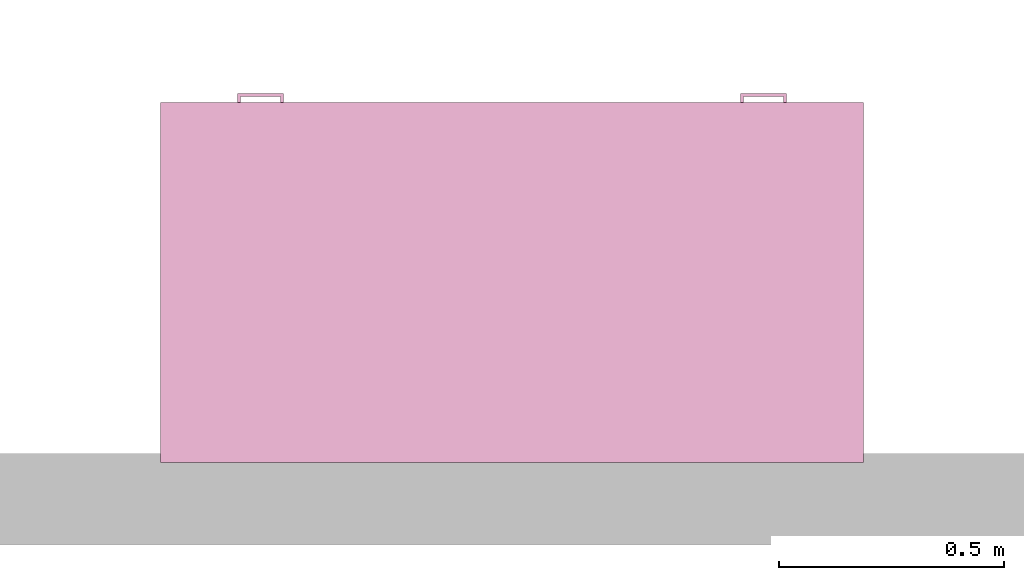
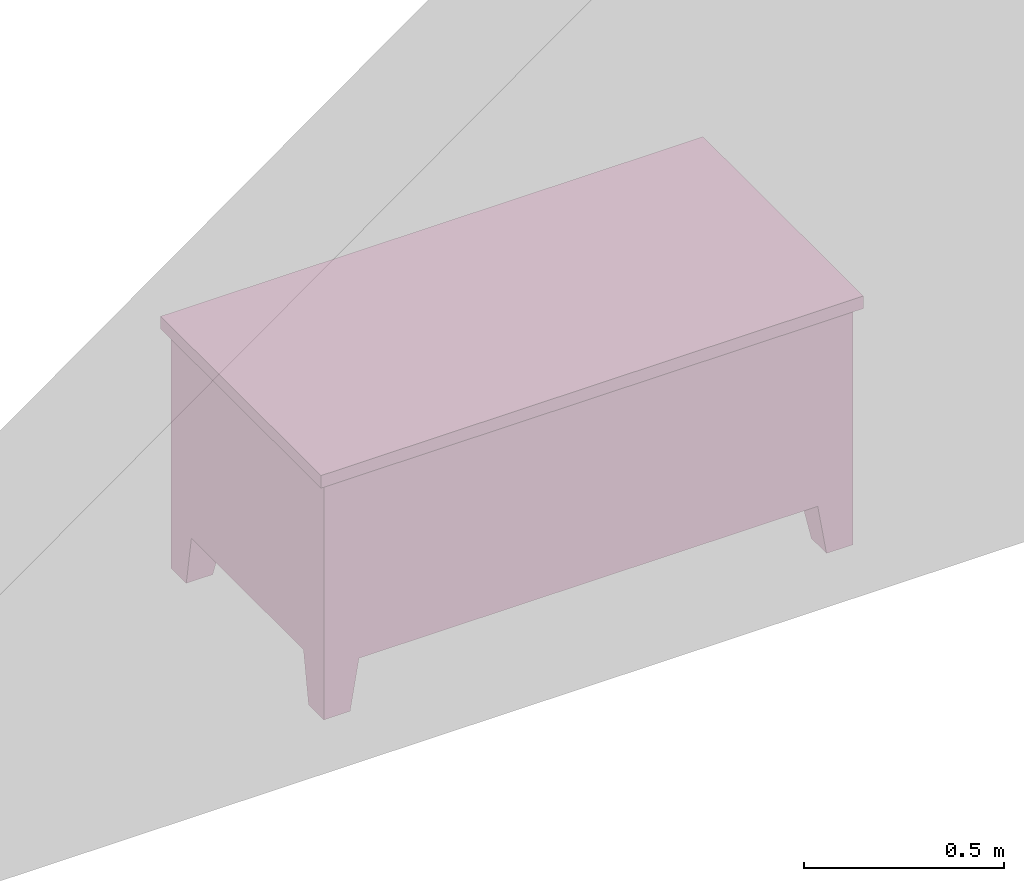
# One storey, part 4 of 4: 1 furnishing.
"""IFC2X3 building model written with IfcOpenShell, lengths in feet."""

from ifc_helpers import new_model, entity, si_unit, converted_unit, derived_unit, direction, frame, origin, place, context, subcontext, project, spatial, faceted_brep, source, transform, mapped, material, material_list, type_object, type_shapes, element, save


model = new_model("IFC2X3")

# Units and contexts
model_context = context("Model", 3, precision=0.0001, world=origin(), true_north=direction((6.123031769111886e-17, 1.0)))
body_context = subcontext(model_context, "Body", "Model", "MODEL_VIEW")
ifc_project = project(units=[converted_unit("LENGTHUNIT", "FOOT", entity("IfcRatioMeasure", 0.3048), si_unit("LENGTHUNIT", "METRE"), dimensions=[1, 0, 0, 0, 0, 0, 0]), converted_unit("AREAUNIT", "SQUARE FOOT", entity("IfcRatioMeasure", 0.09290304), si_unit("AREAUNIT", "SQUARE_METRE"), dimensions=[2, 0, 0, 0, 0, 0, 0]), converted_unit("VOLUMEUNIT", "CUBIC FOOT", entity("IfcRatioMeasure", 0.028316846592000004), si_unit("VOLUMEUNIT", "CUBIC_METRE"), dimensions=[3, 0, 0, 0, 0, 0, 0]), converted_unit("PLANEANGLEUNIT", "DEGREE", entity("IfcRatioMeasure", 0.017453292519943278), si_unit("PLANEANGLEUNIT", "RADIAN"), dimensions=[0, 0, 0, 0, 0, 0, 0]), si_unit("MASSUNIT", "GRAM", prefix="KILO"), derived_unit("MASSDENSITYUNIT", [(si_unit("MASSUNIT", "GRAM", prefix="KILO"), 1), (si_unit("LENGTHUNIT", "METRE"), -3)]), derived_unit("MOMENTOFINERTIAUNIT", [(si_unit("LENGTHUNIT", "METRE"), 4)]), si_unit("TIMEUNIT", "SECOND"), si_unit("FREQUENCYUNIT", "HERTZ"), si_unit("THERMODYNAMICTEMPERATUREUNIT", "DEGREE_CELSIUS"), derived_unit("THERMALTRANSMITTANCEUNIT", [(si_unit("MASSUNIT", "GRAM", prefix="KILO"), 1), (si_unit("THERMODYNAMICTEMPERATUREUNIT", "KELVIN"), -1), (si_unit("TIMEUNIT", "SECOND"), -3)]), derived_unit("VOLUMETRICFLOWRATEUNIT", [(si_unit("LENGTHUNIT", "METRE"), 3), (si_unit("TIMEUNIT", "SECOND"), -1)]), derived_unit("MASSFLOWRATEUNIT", [(si_unit("MASSUNIT", "GRAM", prefix="KILO"), 1), (si_unit("TIMEUNIT", "SECOND"), -1)]), derived_unit("ROTATIONALFREQUENCYUNIT", [(si_unit("TIMEUNIT", "SECOND"), -1)]), si_unit("ELECTRICCURRENTUNIT", "AMPERE"), si_unit("ELECTRICVOLTAGEUNIT", "VOLT"), si_unit("POWERUNIT", "WATT"), si_unit("FORCEUNIT", "NEWTON"), si_unit("ILLUMINANCEUNIT", "LUX"), si_unit("LUMINOUSFLUXUNIT", "LUMEN"), si_unit("LUMINOUSINTENSITYUNIT", "CANDELA"), derived_unit("USERDEFINED", [(si_unit("MASSUNIT", "GRAM", prefix="KILO"), -1), (si_unit("LENGTHUNIT", "METRE"), -2), (si_unit("TIMEUNIT", "SECOND"), 3), (si_unit("LUMINOUSFLUXUNIT", "LUMEN"), 1)]), derived_unit("SOUNDPOWERUNIT", [(si_unit("MASSUNIT", "GRAM", prefix="KILO"), 1), (si_unit("LENGTHUNIT", "METRE"), 2), (si_unit("TIMEUNIT", "SECOND"), -3)]), derived_unit("SOUNDPRESSUREUNIT", [(si_unit("MASSUNIT", "GRAM", prefix="KILO"), 1), (si_unit("LENGTHUNIT", "METRE"), -1), (si_unit("TIMEUNIT", "SECOND"), -2)]), derived_unit("LINEARVELOCITYUNIT", [(si_unit("LENGTHUNIT", "METRE"), 1), (si_unit("TIMEUNIT", "SECOND"), -1)]), si_unit("PRESSUREUNIT", "PASCAL"), derived_unit("USERDEFINED", [(si_unit("LENGTHUNIT", "METRE"), -2), (si_unit("MASSUNIT", "GRAM", prefix="KILO"), 1), (si_unit("TIMEUNIT", "SECOND"), -2)]), derived_unit("LINEARFORCEUNIT", [(si_unit("MASSUNIT", "GRAM", prefix="KILO"), 1), (si_unit("LENGTHUNIT", "METRE"), 1), (si_unit("TIMEUNIT", "SECOND"), -2), (si_unit("LENGTHUNIT", "METRE"), -1)]), derived_unit("PLANARFORCEUNIT", [(si_unit("MASSUNIT", "GRAM", prefix="KILO"), 1), (si_unit("LENGTHUNIT", "METRE"), 1), (si_unit("TIMEUNIT", "SECOND"), -2), (si_unit("LENGTHUNIT", "METRE"), -2)])], contexts=[model_context])

# Site, building, storey, space
site_placement = place(None, origin())
site = spatial("IfcSite", under=ifc_project, at=site_placement, CompositionType="ELEMENT")
building_placement = place(site_placement, origin())
building = spatial("IfcBuilding", under=site, at=building_placement, CompositionType="ELEMENT")
storey_placement = place(building_placement, origin())
storey = spatial("IfcBuildingStorey", under=building, at=storey_placement, Name="Level 1", CompositionType="ELEMENT", Elevation=0.0)
space_placement = place(storey_placement, origin())
space = spatial("IfcSpace", under=storey, at=space_placement, CompositionType="ELEMENT", InteriorOrExteriorSpace="INTERNAL")

# Furnishing
ifc_material_1 = material(Name="Laminate, Ivory, Matte")
ifc_material_2 = material(Name="Steel, Chrome Plated")
ifc_material_3 = material(Name="Cherry")
ifc_material_list_1 = material_list([ifc_material_1, ifc_material_1, ifc_material_1, ifc_material_1, ifc_material_1, ifc_material_1, ifc_material_2, ifc_material_2, ifc_material_2, ifc_material_2, ifc_material_3, ifc_material_1, ifc_material_2, ifc_material_2, ifc_material_2, ifc_material_2, ifc_material_2, ifc_material_2])
ifc_material_list_2 = material_list([ifc_material_1, ifc_material_1, ifc_material_1, ifc_material_1, ifc_material_1, ifc_material_1, ifc_material_2, ifc_material_2, ifc_material_2, ifc_material_2, ifc_material_3, ifc_material_1, ifc_material_2, ifc_material_2, ifc_material_2, ifc_material_2, ifc_material_2, ifc_material_2])
furniture_type = type_object("IfcFurnitureType", material=ifc_material_list_2)
shared_shape = source(origin(), body_context, "Body", "Brep", [
    faceted_brep([(3.7291666666666736, 2.5000000000000027, 2.3124999999999996), (3.7291666666666736, 2.5000000000000027, 1.979166666666666), (4.937500000000006, 2.4999999999999987, 1.979166666666666), (4.937500000000006, 2.4999999999999987, 2.3124999999999996), (3.7291666666666736, 2.541666666666613, 2.3124999999999996), (3.7291666666666736, 2.541666666666613, 1.979166666666666), (4.937500000000006, 2.541666666666609, 1.979166666666666), (4.937500000000006, 2.541666666666609, 2.3124999999999996)], [[[0, 1, 2, 3]], [[1, 0, 4, 5]], [[2, 1, 5, 6]], [[3, 2, 6, 7]], [[0, 3, 7, 4]], [[4, 7, 6, 5]]]),
    faceted_brep([(4.937500000000005, 2.541666666666609, 1.916666666666666), (4.937500000000005, 2.541666666666609, 0.5624999999999998), (3.7291666666666736, 2.541666666666613, 0.5624999999999998), (3.7291666666666736, 2.541666666666613, 1.916666666666666), (3.7291666666666736, 2.5000000000000027, 1.916666666666666), (4.937500000000005, 2.4999999999999987, 1.916666666666666), (3.7291666666666736, 2.5000000000000027, 0.5624999999999998), (4.937500000000005, 2.4999999999999987, 0.5624999999999998)], [[[0, 1, 2, 3]], [[4, 5, 0, 3]], [[6, 4, 3, 2]], [[7, 6, 2, 1]], [[5, 7, 1, 0]], [[5, 4, 6, 7]]]),
    faceted_brep([(1.2708333333333333, 2.499999999999999, 2.3125), (0.0625, 2.499999999999999, 2.3125), (0.0625, 2.499999999999999, 1.9791666666666667), (1.2708333333333333, 2.499999999999999, 1.9791666666666667), (1.2708333333333333, 2.541666666666672, 2.3125), (0.0625, 2.541666666666672, 2.3125), (0.0625, 2.541666666666672, 1.9791666666666667), (1.2708333333333333, 2.541666666666672, 1.9791666666666667)], [[[0, 1, 2, 3]], [[1, 0, 4, 5]], [[2, 1, 5, 6]], [[3, 2, 6, 7]], [[0, 3, 7, 4]], [[4, 7, 6, 5]]]),
    faceted_brep([(0.0625, 2.541666666666672, 1.9166666666666667), (1.2708333333333333, 2.541666666666672, 1.9166666666666667), (1.2708333333333333, 2.541666666666672, 1.5833333333333335), (0.0625, 2.541666666666672, 1.5833333333333335), (0.0625, 2.499999999999999, 1.5833333333333335), (0.0625, 2.499999999999999, 1.9166666666666667), (1.2708333333333333, 2.499999999999999, 1.5833333333333335), (1.2708333333333333, 2.499999999999999, 1.9166666666666667)], [[[0, 1, 2, 3]], [[4, 5, 0, 3]], [[6, 4, 3, 2]], [[7, 6, 2, 1]], [[5, 7, 1, 0]], [[5, 4, 6, 7]]]),
    faceted_brep([(0.0625, 2.499999999999999, 0.5625), (0.0625, 2.499999999999999, 1.1250000000000002), (0.0625, 2.541666666666672, 1.1250000000000002), (0.0625, 2.541666666666672, 0.5625), (1.2708333333333333, 2.499999999999999, 0.5625), (1.2708333333333333, 2.541666666666672, 0.5625), (1.2708333333333333, 2.499999999999999, 1.1250000000000002), (1.2708333333333333, 2.541666666666672, 1.1250000000000002)], [[[0, 1, 2, 3]], [[4, 0, 3, 5]], [[6, 4, 5, 7]], [[1, 6, 7, 2]], [[2, 7, 5, 3]], [[1, 0, 4, 6]]]),
    faceted_brep([(0.0625, 2.499999999999999, 1.1875000000000002), (0.0625, 2.499999999999999, 1.5208333333333335), (0.0625, 2.541666666666672, 1.5208333333333335), (0.0625, 2.541666666666672, 1.1875000000000002), (1.2708333333333333, 2.499999999999999, 1.1875000000000002), (1.2708333333333333, 2.541666666666672, 1.1875000000000002), (1.2708333333333333, 2.499999999999999, 1.5208333333333335), (1.2708333333333333, 2.541666666666672, 1.5208333333333335)], [[[0, 1, 2, 3]], [[4, 0, 3, 5]], [[6, 4, 5, 7]], [[1, 6, 7, 2]], [[2, 7, 5, 3]], [[1, 0, 4, 6]]]),
    faceted_brep([(4.666666666666591, 2.499999999999999, 0.5000000000000001), (4.666666666666591, 2.166666666666664, 0.5), (5.0, 2.166666666666664, 0.5), (5.0, 2.499999999999999, 0.5), (4.749999999999922, 2.4999999999999996, 0.0), (5.0, 2.4999999999999996, 0.0), (5.0, 2.2499999999999996, 0.0), (4.749999999999922, 2.2499999999999996, 0.0)], [[[0, 1, 2, 3]], [[4, 5, 6, 7]], [[4, 7, 1, 0]], [[7, 6, 2, 1]], [[6, 5, 3, 2]], [[5, 4, 0, 3]]]),
    faceted_brep([(4.666666666666661, 0.0, 0.5), (5.0, 0.0, 0.5), (5.0, 0.3333333333333343, 0.5), (4.666666666666661, 0.3333333333333343, 0.49999999999999994), (4.749999999999995, 0.0, 0.0), (4.749999999999995, 0.2499999999999996, 0.0), (5.0, 0.2499999999999996, 0.0), (5.0, 0.0, 0.0)], [[[0, 1, 2, 3]], [[4, 5, 6, 7]], [[4, 7, 1, 0]], [[7, 6, 2, 1]], [[6, 5, 3, 2]], [[5, 4, 0, 3]]]),
    faceted_brep([(0.3333333333333332, 0.0, 0.5), (0.3333333333333332, 0.33333333333333376, 0.5), (0.0, 0.33333333333333376, 0.5), (0.0, 0.0, 0.5), (0.2500000000000001, 0.0, 0.0), (0.0, 0.0, 0.0), (0.0, 0.24999999999999867, 0.0), (0.2500000000000001, 0.24999999999999867, 0.0)], [[[0, 1, 2, 3]], [[4, 5, 6, 7]], [[4, 7, 1, 0]], [[7, 6, 2, 1]], [[6, 5, 3, 2]], [[5, 4, 0, 3]]]),
    faceted_brep([(0.33333333333333326, 2.5000000000000044, 0.5), (0.0, 2.5000000000000044, 0.5), (0.0, 2.1666666666666723, 0.5), (0.3333333333333332, 2.1666666666666723, 0.5), (0.2499999999999992, 2.500000000000004, 0.0), (0.24999999999999917, 2.2500000000000058, 0.0), (0.0, 2.2500000000000058, 0.0), (0.0, 2.500000000000004, 0.0)], [[[0, 1, 2, 3]], [[4, 5, 6, 7]], [[4, 7, 1, 0]], [[7, 6, 2, 1]], [[6, 5, 3, 2]], [[5, 4, 0, 3]]]),
    faceted_brep([(5.062500000000025, 2.562499999999988, 2.499999999999998), (-0.06249999999999925, 2.562499999999988, 2.499999999999998), (-0.06249999999999925, -0.0625000000000151, 2.499999999999998), (5.062500000000025, -0.0625000000000151, 2.499999999999998), (5.062500000000025, 2.562499999999988, 2.3749999999999996), (5.062500000000025, -0.0625000000000151, 2.3749999999999996), (-0.06249999999999925, -0.0625000000000151, 2.3749999999999996), (-0.06249999999999911, 2.562499999999988, 2.3749999999999996)], [[[0, 1, 2, 3]], [[4, 5, 6, 7]], [[1, 0, 4, 7]], [[2, 1, 7, 6]], [[3, 2, 6, 5]], [[0, 3, 5, 4]]]),
    faceted_brep([(1.3333333333333333, 2.499999999999999, 2.3749999999999996), (0.0, 2.499999999999999, 2.3749999999999996), (0.0, 0.0, 2.3749999999999996), (5.0, 0.0, 2.3749999999999996), (5.0, 2.499999999999999, 2.3749999999999996), (3.6666666666667087, 2.499999999999999, 2.3749999999999996), (3.6666666666667087, 0.1666666666666674, 2.3749999999999996), (1.3333333333333333, 0.1666666666666674, 2.3749999999999996), (1.3333333333333333, 2.499999999999999, 0.5), (1.333333333333333, 0.1666666666666674, 0.5), (3.6666666666667087, 0.1666666666666674, 0.5), (3.6666666666667087, 2.499999999999999, 0.5), (5.0, 2.499999999999999, 0.5), (5.0, 0.0, 0.5), (0.0, 0.0, 0.5), (0.0, 2.499999999999999, 0.5)], [[[0, 1, 2, 3, 4, 5, 6, 7]], [[8, 9, 10, 11, 12, 13, 14, 15]], [[1, 0, 8, 15]], [[2, 1, 15, 14]], [[3, 2, 14, 13]], [[4, 3, 13, 12]], [[5, 4, 12, 11]], [[6, 5, 11, 10]], [[7, 6, 10, 9]], [[0, 7, 9, 8]]]),
    faceted_brep([(4.479166666666591, 2.54166666666663, 1.7916666666666643), (4.479166666666591, 2.54166666666663, 1.7499999999999742), (4.499999999999923, 2.54166666666663, 1.7499999999999742), (4.499999999999923, 2.54166666666663, 1.7916666666666643), (4.479166666666591, 2.6041666666666297, 1.7916666666666643), (4.479166666666591, 2.6041666666666297, 1.7499999999999742), (4.499999999999923, 2.624999999999962, 1.7499999999999742), (4.499999999999923, 2.624999999999962, 1.7916666666666643), (4.187499999999925, 2.6041666666666297, 1.7916666666666643), (4.187499999999925, 2.6041666666666297, 1.7499999999999742), (4.166666666666593, 2.624999999999962, 1.7499999999999742), (4.166666666666593, 2.624999999999962, 1.7916666666666643), (4.187499999999925, 2.54166666666663, 1.7916666666666643), (4.187499999999925, 2.54166666666663, 1.7499999999999742), (4.166666666666593, 2.54166666666663, 1.7499999999999742), (4.166666666666593, 2.54166666666663, 1.7916666666666643)], [[[0, 1, 2, 3]], [[1, 0, 4, 5]], [[2, 1, 5, 6]], [[3, 2, 6, 7]], [[0, 3, 7, 4]], [[5, 4, 8, 9]], [[6, 5, 9, 10]], [[7, 6, 10, 11]], [[4, 7, 11, 8]], [[9, 8, 12, 13]], [[10, 9, 13, 14]], [[11, 10, 14, 15]], [[8, 11, 15, 12]], [[12, 15, 14, 13]]]),
    faceted_brep([(4.47916666666659, 2.54166666666663, 2.145833333333332), (4.47916666666659, 2.54166666666663, 2.1874999999999982), (4.47916666666659, 2.6041666666666288, 2.1874999999999982), (4.47916666666659, 2.6041666666666288, 2.145833333333332), (4.499999999999924, 2.54166666666663, 2.145833333333332), (4.499999999999924, 2.6249999999999627, 2.145833333333332), (4.499999999999924, 2.54166666666663, 2.1874999999999982), (4.499999999999924, 2.6249999999999627, 2.1874999999999982), (4.187499999999926, 2.6041666666666288, 2.1874999999999982), (4.187499999999926, 2.6041666666666288, 2.145833333333332), (4.166666666666592, 2.6249999999999627, 2.145833333333332), (4.166666666666592, 2.6249999999999627, 2.1874999999999982), (4.187499999999926, 2.54166666666663, 2.1874999999999982), (4.166666666666592, 2.54166666666663, 2.1874999999999982), (4.166666666666592, 2.54166666666663, 2.145833333333332), (4.187499999999926, 2.54166666666663, 2.145833333333332)], [[[0, 1, 2, 3]], [[4, 0, 3, 5]], [[6, 4, 5, 7]], [[1, 6, 7, 2]], [[3, 2, 8, 9]], [[5, 3, 9, 10]], [[7, 5, 10, 11]], [[2, 7, 11, 8]], [[12, 13, 14, 15]], [[9, 8, 12, 15]], [[10, 9, 15, 14]], [[11, 10, 14, 13]], [[8, 11, 13, 12]], [[1, 0, 4, 6]]]),
    faceted_brep([(0.5208333333333328, 2.54166666666663, 1.0), (0.49999999999999933, 2.54166666666663, 1.0), (0.49999999999999933, 2.54166666666663, 0.9583333333333334), (0.5208333333333328, 2.54166666666663, 0.9583333333333334), (0.5208333333333328, 2.604166666666648, 1.0), (0.49999999999999933, 2.6249999999999813, 1.0), (0.49999999999999933, 2.6249999999999813, 0.9583333333333335), (0.5208333333333327, 2.604166666666648, 0.9583333333333335), (0.8124999999999991, 2.604166666666648, 1.0), (0.8333333333333326, 2.6249999999999813, 1.0), (0.8333333333333326, 2.6249999999999813, 0.9583333333333335), (0.8124999999999991, 2.604166666666648, 0.9583333333333335), (0.8124999999999991, 2.54166666666663, 1.0), (0.8333333333333326, 2.54166666666663, 1.0), (0.8333333333333326, 2.54166666666663, 0.9583333333333334), (0.8124999999999991, 2.54166666666663, 0.9583333333333334)], [[[0, 1, 2, 3]], [[1, 0, 4, 5]], [[2, 1, 5, 6]], [[3, 2, 6, 7]], [[0, 3, 7, 4]], [[5, 4, 8, 9]], [[6, 5, 9, 10]], [[7, 6, 10, 11]], [[4, 7, 11, 8]], [[9, 8, 12, 13]], [[10, 9, 13, 14]], [[11, 10, 14, 15]], [[8, 11, 15, 12]], [[12, 15, 14, 13]]]),
    faceted_brep([(0.49999999999999933, 2.54166666666663, 1.3958333333333388), (0.5208333333333328, 2.54166666666663, 1.3958333333333388), (0.5208333333333328, 2.604166666666648, 1.3958333333333388), (0.49999999999999933, 2.6249999999999813, 1.3958333333333388), (0.49999999999999933, 2.54166666666663, 1.3541666666666723), (0.49999999999999933, 2.6249999999999813, 1.3541666666666723), (0.5208333333333328, 2.54166666666663, 1.3541666666666723), (0.5208333333333327, 2.604166666666648, 1.3541666666666723), (0.8124999999999991, 2.604166666666648, 1.3958333333333388), (0.8333333333333326, 2.6249999999999813, 1.3958333333333388), (0.8333333333333326, 2.6249999999999813, 1.3541666666666723), (0.8124999999999991, 2.604166666666648, 1.3541666666666723), (0.8124999999999991, 2.54166666666663, 1.3958333333333388), (0.8333333333333326, 2.54166666666663, 1.3958333333333388), (0.8333333333333326, 2.54166666666663, 1.3541666666666723), (0.8124999999999991, 2.54166666666663, 1.3541666666666723)], [[[0, 1, 2, 3]], [[4, 0, 3, 5]], [[6, 4, 5, 7]], [[1, 6, 7, 2]], [[3, 2, 8, 9]], [[5, 3, 9, 10]], [[7, 5, 10, 11]], [[2, 7, 11, 8]], [[9, 8, 12, 13]], [[10, 9, 13, 14]], [[11, 10, 14, 15]], [[8, 11, 15, 12]], [[12, 15, 14, 13]], [[1, 0, 4, 6]]]),
    faceted_brep([(0.49999999999999933, 2.54166666666663, 1.7916666666666659), (0.5208333333333328, 2.54166666666663, 1.7916666666666659), (0.5208333333333328, 2.604166666666648, 1.7916666666666659), (0.49999999999999933, 2.6249999999999813, 1.7916666666666659), (0.49999999999999933, 2.54166666666663, 1.7499999999999993), (0.49999999999999933, 2.6249999999999813, 1.7499999999999993), (0.5208333333333328, 2.54166666666663, 1.7499999999999993), (0.5208333333333327, 2.604166666666648, 1.7499999999999993), (0.8124999999999991, 2.604166666666648, 1.7916666666666659), (0.8333333333333326, 2.6249999999999813, 1.7916666666666659), (0.8333333333333326, 2.6249999999999813, 1.7499999999999993), (0.8124999999999991, 2.604166666666648, 1.7499999999999993), (0.8124999999999991, 2.54166666666663, 1.7916666666666659), (0.8333333333333326, 2.54166666666663, 1.7916666666666659), (0.8333333333333326, 2.54166666666663, 1.7499999999999993), (0.8124999999999991, 2.54166666666663, 1.7499999999999993)], [[[0, 1, 2, 3]], [[4, 0, 3, 5]], [[6, 4, 5, 7]], [[1, 6, 7, 2]], [[3, 2, 8, 9]], [[5, 3, 9, 10]], [[7, 5, 10, 11]], [[2, 7, 11, 8]], [[9, 8, 12, 13]], [[10, 9, 13, 14]], [[11, 10, 14, 15]], [[8, 11, 15, 12]], [[12, 15, 14, 13]], [[1, 0, 4, 6]]]),
    faceted_brep([(0.49999999999999933, 2.54166666666663, 2.1875000000000053), (0.5208333333333328, 2.54166666666663, 2.1875000000000053), (0.5208333333333328, 2.604166666666648, 2.1875000000000053), (0.49999999999999933, 2.6249999999999813, 2.1875000000000053), (0.49999999999999933, 2.54166666666663, 2.1458333333333393), (0.49999999999999933, 2.6249999999999813, 2.1458333333333393), (0.5208333333333328, 2.54166666666663, 2.1458333333333393), (0.5208333333333327, 2.604166666666648, 2.1458333333333393), (0.8124999999999991, 2.604166666666648, 2.1875000000000053), (0.8333333333333326, 2.6249999999999813, 2.1875000000000053), (0.8333333333333326, 2.6249999999999813, 2.1458333333333393), (0.8124999999999991, 2.604166666666648, 2.1458333333333393), (0.8124999999999991, 2.54166666666663, 2.1875000000000053), (0.8124999999999991, 2.54166666666663, 2.1458333333333393), (0.8333333333333326, 2.54166666666663, 2.1458333333333393), (0.8333333333333326, 2.54166666666663, 2.1875000000000053)], [[[0, 1, 2, 3]], [[4, 0, 3, 5]], [[6, 4, 5, 7]], [[1, 6, 7, 2]], [[3, 2, 8, 9]], [[5, 3, 9, 10]], [[7, 5, 10, 11]], [[2, 7, 11, 8]], [[12, 13, 14, 15]], [[9, 8, 12, 15]], [[10, 9, 15, 14]], [[11, 10, 14, 13]], [[8, 11, 13, 12]], [[1, 0, 4, 6]]]),
])
type_shapes(furniture_type, [shared_shape])
furnishing_placement = place(space_placement, frame((-31.089519852702985, 13.592071449390382, 0.0)))
element("IfcFurnishingElement", 1, at=furnishing_placement, inside=space, type_object=furniture_type, material=ifc_material_list_1, context=body_context, shape_type="MappedRepresentation", body=[
    mapped(shared_shape, transform((0.0, 0.0, 0.0), scale=1.0)),
])

save(model, "model.ifc")
